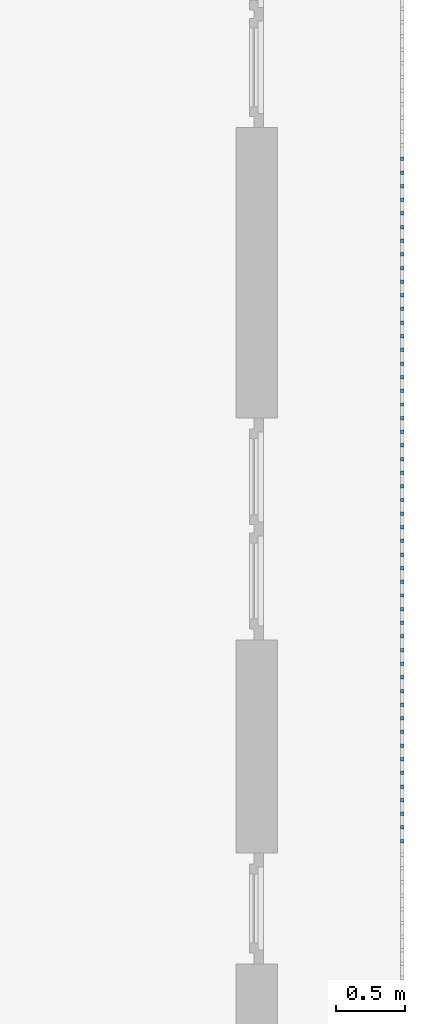
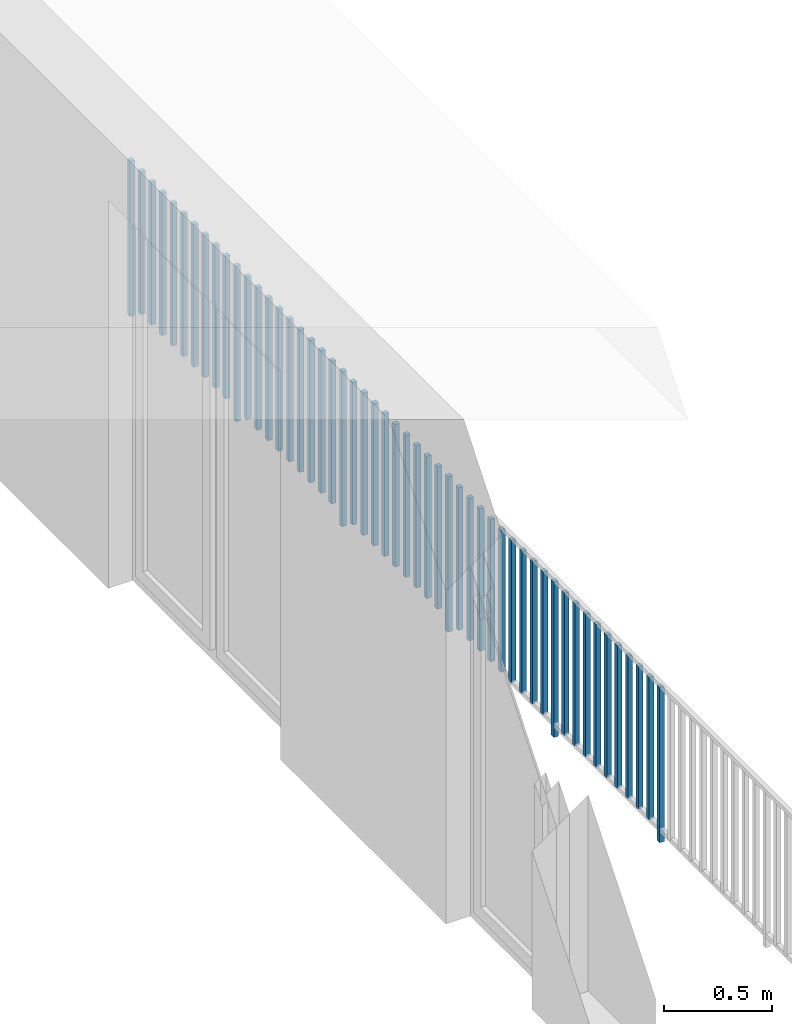
# One storey, part 38 of 48: 51 building element parts, 1 element without a shape of its own.
"""IFC4 building model written with IfcOpenShell, lengths in metres."""

from ifc_helpers import new_model, entity, si_unit, converted_unit, derived_unit, direction, frame, origin_with_axes, place, context, subcontext, project, spatial, polygons, material, type_object, element, aggregate, save


model = new_model("IFC4")

# Units and contexts
model_context = context("Model", 3, precision=1e-05, world=origin_with_axes(), true_north=direction((0.0, 1.0)))
body_context = subcontext(model_context, "Body", "Model", "MODEL_VIEW")
ifc_project = project(units=[si_unit("LENGTHUNIT", "METRE"), si_unit("AREAUNIT", "SQUARE_METRE"), si_unit("VOLUMEUNIT", "CUBIC_METRE"), converted_unit("PLANEANGLEUNIT", "DEGREE", entity("IfcPlaneAngleMeasure", 0.0174532925199), si_unit("PLANEANGLEUNIT", "RADIAN"), dimensions=[0, 0, 0, 0, 0, 0, 0]), converted_unit("TIMEUNIT", "Year", entity("IfcTimeMeasure", 31556926.0), si_unit("TIMEUNIT", "SECOND"), dimensions=[0, 0, 1, 0, 0, 0, 0]), si_unit("MASSUNIT", "GRAM", prefix="KILO"), si_unit("THERMODYNAMICTEMPERATUREUNIT", "DEGREE_CELSIUS"), si_unit("LUMINOUSINTENSITYUNIT", "LUMEN"), si_unit("ENERGYUNIT", "JOULE", prefix="MEGA"), derived_unit("THERMALCONDUCTANCEUNIT", [(si_unit("POWERUNIT", "WATT"), 1), (si_unit("LENGTHUNIT", "METRE"), -1), (si_unit("THERMODYNAMICTEMPERATUREUNIT", "KELVIN"), -1)]), derived_unit("SPECIFICHEATCAPACITYUNIT", [(si_unit("ENERGYUNIT", "JOULE"), 1), (si_unit("MASSUNIT", "GRAM", prefix="KILO"), -1), (si_unit("THERMODYNAMICTEMPERATUREUNIT", "KELVIN"), -1)]), derived_unit("MASSDENSITYUNIT", [(si_unit("MASSUNIT", "GRAM", prefix="KILO"), 1), (si_unit("VOLUMEUNIT", "CUBIC_METRE"), -1)])], contexts=[model_context])

# Site, building, storey
site_placement = place(None, origin_with_axes())
site = spatial("IfcSite", under=ifc_project, at=site_placement, CompositionType="ELEMENT")
building_placement = place(site_placement, origin_with_axes())
building = spatial("IfcBuilding", under=site, at=building_placement, CompositionType="ELEMENT")
storey_placement = place(building_placement, frame((0.0, 0.0, 3.4), z_axis=(0.0, 0.0, 1.0), x_axis=(1.0, 0.0, 0.0)))
storey = spatial("IfcBuildingStorey", under=building, at=storey_placement, Name="1. Geschoss", CompositionType="ELEMENT", Elevation=3.4)

# Railing, building element parts
railing_type = type_object("IfcRailingType", PredefinedType="NOTDEFINED")
railing_placement = place(storey_placement, frame((10.2378006196, 9.82118776896, 0.0), z_axis=(0.0, 0.0, 1.0), x_axis=(1.0, 0.0, 0.0)))
railing = element("IfcRailing", 1, at=railing_placement, inside=storey, type_object=railing_type, PredefinedType="NOTDEFINED")
ifc_material = material()
building_element_part_1_placement = place(railing_placement, origin_with_axes())
building_element_part_1 = element("IfcBuildingElementPart", 2, at=building_element_part_1_placement, material=ifc_material, PredefinedType="NOTDEFINED", context=body_context, shape_type="Tessellation", body=[
    polygons([(0.0125, -17.6875, 0.0), (-0.0125, -17.6875, 0.0), (-0.0125, -17.6875, 0.88), (0.0125, -17.6875, 0.88), (0.0125, -17.7125, 0.0), (-0.0125, -17.7125, 0.0), (-0.0125, -17.7125, 0.88), (0.0125, -17.7125, 0.88)], [[[1, 2, 3, 4]], [[1, 5, 6, 2]], [[2, 6, 7, 3]], [[4, 3, 7, 8]], [[5, 1, 4, 8]], [[6, 5, 8, 7]]], closed=True),
])
building_element_part_2_placement = place(railing_placement, origin_with_axes())
building_element_part_2 = element("IfcBuildingElementPart", 3, at=building_element_part_2_placement, material=ifc_material, PredefinedType="NOTDEFINED", context=body_context, shape_type="Tessellation", body=[
    polygons([(0.0125, -17.5891666667, 0.07), (-0.0125, -17.5891666667, 0.07), (-0.0125, -17.5891666667, 0.8775), (0.0125, -17.5891666667, 0.8775), (0.0125, -17.6141666667, 0.07), (-0.0125, -17.6141666667, 0.07), (-0.0125, -17.6141666667, 0.8775), (0.0125, -17.6141666667, 0.8775)], [[[1, 2, 3, 4]], [[1, 5, 6, 2]], [[2, 6, 7, 3]], [[4, 3, 7, 8]], [[5, 1, 4, 8]], [[6, 5, 8, 7]]], closed=True),
])
building_element_part_3_placement = place(railing_placement, origin_with_axes())
building_element_part_3 = element("IfcBuildingElementPart", 4, at=building_element_part_3_placement, material=ifc_material, PredefinedType="NOTDEFINED", context=body_context, shape_type="Tessellation", body=[
    polygons([(0.0125, -17.4908333333, 0.07), (-0.0125, -17.4908333333, 0.07), (-0.0125, -17.4908333333, 0.8775), (0.0125, -17.4908333333, 0.8775), (0.0125, -17.5158333333, 0.07), (-0.0125, -17.5158333333, 0.07), (-0.0125, -17.5158333333, 0.8775), (0.0125, -17.5158333333, 0.8775)], [[[1, 2, 3, 4]], [[1, 5, 6, 2]], [[2, 6, 7, 3]], [[4, 3, 7, 8]], [[5, 1, 4, 8]], [[6, 5, 8, 7]]], closed=True),
])
building_element_part_4_placement = place(railing_placement, origin_with_axes())
building_element_part_4 = element("IfcBuildingElementPart", 5, at=building_element_part_4_placement, material=ifc_material, PredefinedType="NOTDEFINED", context=body_context, shape_type="Tessellation", body=[
    polygons([(0.0125, -17.3925, 0.07), (-0.0125, -17.3925, 0.07), (-0.0125, -17.3925, 0.8775), (0.0125, -17.3925, 0.8775), (0.0125, -17.4175, 0.07), (-0.0125, -17.4175, 0.07), (-0.0125, -17.4175, 0.8775), (0.0125, -17.4175, 0.8775)], [[[1, 2, 3, 4]], [[1, 5, 6, 2]], [[2, 6, 7, 3]], [[4, 3, 7, 8]], [[5, 1, 4, 8]], [[6, 5, 8, 7]]], closed=True),
])
building_element_part_5_placement = place(railing_placement, origin_with_axes())
building_element_part_5 = element("IfcBuildingElementPart", 6, at=building_element_part_5_placement, material=ifc_material, PredefinedType="NOTDEFINED", context=body_context, shape_type="Tessellation", body=[
    polygons([(0.0125, -17.2941666667, 0.07), (-0.0125, -17.2941666667, 0.07), (-0.0125, -17.2941666667, 0.8775), (0.0125, -17.2941666667, 0.8775), (0.0125, -17.3191666667, 0.07), (-0.0125, -17.3191666667, 0.07), (-0.0125, -17.3191666667, 0.8775), (0.0125, -17.3191666667, 0.8775)], [[[1, 2, 3, 4]], [[1, 5, 6, 2]], [[2, 6, 7, 3]], [[4, 3, 7, 8]], [[5, 1, 4, 8]], [[6, 5, 8, 7]]], closed=True),
])
building_element_part_6_placement = place(railing_placement, origin_with_axes())
building_element_part_6 = element("IfcBuildingElementPart", 7, at=building_element_part_6_placement, material=ifc_material, PredefinedType="NOTDEFINED", context=body_context, shape_type="Tessellation", body=[
    polygons([(0.0125, -17.1958333333, 0.07), (-0.0125, -17.1958333333, 0.07), (-0.0125, -17.1958333333, 0.8775), (0.0125, -17.1958333333, 0.8775), (0.0125, -17.2208333333, 0.07), (-0.0125, -17.2208333333, 0.07), (-0.0125, -17.2208333333, 0.8775), (0.0125, -17.2208333333, 0.8775)], [[[1, 2, 3, 4]], [[1, 5, 6, 2]], [[2, 6, 7, 3]], [[4, 3, 7, 8]], [[5, 1, 4, 8]], [[6, 5, 8, 7]]], closed=True),
])
building_element_part_7_placement = place(railing_placement, origin_with_axes())
building_element_part_7 = element("IfcBuildingElementPart", 8, at=building_element_part_7_placement, material=ifc_material, PredefinedType="NOTDEFINED", context=body_context, shape_type="Tessellation", body=[
    polygons([(0.0125, -17.0975, 0.07), (-0.0125, -17.0975, 0.07), (-0.0125, -17.0975, 0.8775), (0.0125, -17.0975, 0.8775), (0.0125, -17.1225, 0.07), (-0.0125, -17.1225, 0.07), (-0.0125, -17.1225, 0.8775), (0.0125, -17.1225, 0.8775)], [[[1, 2, 3, 4]], [[1, 5, 6, 2]], [[2, 6, 7, 3]], [[4, 3, 7, 8]], [[5, 1, 4, 8]], [[6, 5, 8, 7]]], closed=True),
])
building_element_part_8_placement = place(railing_placement, origin_with_axes())
building_element_part_8 = element("IfcBuildingElementPart", 9, at=building_element_part_8_placement, material=ifc_material, PredefinedType="NOTDEFINED", context=body_context, shape_type="Tessellation", body=[
    polygons([(0.0125, -16.9991666667, 0.07), (-0.0125, -16.9991666667, 0.07), (-0.0125, -16.9991666667, 0.8775), (0.0125, -16.9991666667, 0.8775), (0.0125, -17.0241666667, 0.07), (-0.0125, -17.0241666667, 0.07), (-0.0125, -17.0241666667, 0.8775), (0.0125, -17.0241666667, 0.8775)], [[[1, 2, 3, 4]], [[1, 5, 6, 2]], [[2, 6, 7, 3]], [[4, 3, 7, 8]], [[5, 1, 4, 8]], [[6, 5, 8, 7]]], closed=True),
])
building_element_part_9_placement = place(railing_placement, origin_with_axes())
building_element_part_9 = element("IfcBuildingElementPart", 10, at=building_element_part_9_placement, material=ifc_material, PredefinedType="NOTDEFINED", context=body_context, shape_type="Tessellation", body=[
    polygons([(0.0125, -16.9008333333, 0.07), (-0.0125, -16.9008333333, 0.07), (-0.0125, -16.9008333333, 0.8775), (0.0125, -16.9008333333, 0.8775), (0.0125, -16.9258333333, 0.07), (-0.0125, -16.9258333333, 0.07), (-0.0125, -16.9258333333, 0.8775), (0.0125, -16.9258333333, 0.8775)], [[[1, 2, 3, 4]], [[1, 5, 6, 2]], [[2, 6, 7, 3]], [[4, 3, 7, 8]], [[5, 1, 4, 8]], [[6, 5, 8, 7]]], closed=True),
])
building_element_part_10_placement = place(railing_placement, origin_with_axes())
building_element_part_10 = element("IfcBuildingElementPart", 11, at=building_element_part_10_placement, material=ifc_material, PredefinedType="NOTDEFINED", context=body_context, shape_type="Tessellation", body=[
    polygons([(0.0125, -16.8025, 0.07), (-0.0125, -16.8025, 0.07), (-0.0125, -16.8025, 0.8775), (0.0125, -16.8025, 0.8775), (0.0125, -16.8275, 0.07), (-0.0125, -16.8275, 0.07), (-0.0125, -16.8275, 0.8775), (0.0125, -16.8275, 0.8775)], [[[1, 2, 3, 4]], [[1, 5, 6, 2]], [[2, 6, 7, 3]], [[4, 3, 7, 8]], [[5, 1, 4, 8]], [[6, 5, 8, 7]]], closed=True),
])
building_element_part_11_placement = place(railing_placement, origin_with_axes())
building_element_part_11 = element("IfcBuildingElementPart", 12, at=building_element_part_11_placement, material=ifc_material, PredefinedType="NOTDEFINED", context=body_context, shape_type="Tessellation", body=[
    polygons([(0.0125, -16.7041666667, 0.0), (-0.0125, -16.7041666667, 0.0), (-0.0125, -16.7041666667, 0.88), (0.0125, -16.7041666667, 0.88), (0.0125, -16.7291666667, 0.0), (-0.0125, -16.7291666667, 0.0), (-0.0125, -16.7291666667, 0.88), (0.0125, -16.7291666667, 0.88)], [[[1, 2, 3, 4]], [[1, 5, 6, 2]], [[2, 6, 7, 3]], [[4, 3, 7, 8]], [[5, 1, 4, 8]], [[6, 5, 8, 7]]], closed=True),
])
building_element_part_12_placement = place(railing_placement, origin_with_axes())
building_element_part_12 = element("IfcBuildingElementPart", 13, at=building_element_part_12_placement, material=ifc_material, PredefinedType="NOTDEFINED", context=body_context, shape_type="Tessellation", body=[
    polygons([(0.0125, -16.6058333333, 0.07), (-0.0125, -16.6058333333, 0.07), (-0.0125, -16.6058333333, 0.8775), (0.0125, -16.6058333333, 0.8775), (0.0125, -16.6308333333, 0.07), (-0.0125, -16.6308333333, 0.07), (-0.0125, -16.6308333333, 0.8775), (0.0125, -16.6308333333, 0.8775)], [[[1, 2, 3, 4]], [[1, 5, 6, 2]], [[2, 6, 7, 3]], [[4, 3, 7, 8]], [[5, 1, 4, 8]], [[6, 5, 8, 7]]], closed=True),
])
building_element_part_13_placement = place(railing_placement, origin_with_axes())
building_element_part_13 = element("IfcBuildingElementPart", 14, at=building_element_part_13_placement, material=ifc_material, PredefinedType="NOTDEFINED", context=body_context, shape_type="Tessellation", body=[
    polygons([(0.0125, -16.5075, 0.07), (-0.0125, -16.5075, 0.07), (-0.0125, -16.5075, 0.8775), (0.0125, -16.5075, 0.8775), (0.0125, -16.5325, 0.07), (-0.0125, -16.5325, 0.07), (-0.0125, -16.5325, 0.8775), (0.0125, -16.5325, 0.8775)], [[[1, 2, 3, 4]], [[1, 5, 6, 2]], [[2, 6, 7, 3]], [[4, 3, 7, 8]], [[5, 1, 4, 8]], [[6, 5, 8, 7]]], closed=True),
])
building_element_part_14_placement = place(railing_placement, origin_with_axes())
building_element_part_14 = element("IfcBuildingElementPart", 15, at=building_element_part_14_placement, material=ifc_material, PredefinedType="NOTDEFINED", context=body_context, shape_type="Tessellation", body=[
    polygons([(0.0125, -16.4091666667, 0.07), (-0.0125, -16.4091666667, 0.07), (-0.0125, -16.4091666667, 0.8775), (0.0125, -16.4091666667, 0.8775), (0.0125, -16.4341666667, 0.07), (-0.0125, -16.4341666667, 0.07), (-0.0125, -16.4341666667, 0.8775), (0.0125, -16.4341666667, 0.8775)], [[[1, 2, 3, 4]], [[1, 5, 6, 2]], [[2, 6, 7, 3]], [[4, 3, 7, 8]], [[5, 1, 4, 8]], [[6, 5, 8, 7]]], closed=True),
])
building_element_part_15_placement = place(railing_placement, origin_with_axes())
building_element_part_15 = element("IfcBuildingElementPart", 16, at=building_element_part_15_placement, material=ifc_material, PredefinedType="NOTDEFINED", context=body_context, shape_type="Tessellation", body=[
    polygons([(0.0125, -16.3108333333, 0.07), (-0.0125, -16.3108333333, 0.07), (-0.0125, -16.3108333333, 0.8775), (0.0125, -16.3108333333, 0.8775), (0.0125, -16.3358333333, 0.07), (-0.0125, -16.3358333333, 0.07), (-0.0125, -16.3358333333, 0.8775), (0.0125, -16.3358333333, 0.8775)], [[[1, 2, 3, 4]], [[1, 5, 6, 2]], [[2, 6, 7, 3]], [[4, 3, 7, 8]], [[5, 1, 4, 8]], [[6, 5, 8, 7]]], closed=True),
])
building_element_part_16_placement = place(railing_placement, origin_with_axes())
building_element_part_16 = element("IfcBuildingElementPart", 17, at=building_element_part_16_placement, material=ifc_material, PredefinedType="NOTDEFINED", context=body_context, shape_type="Tessellation", body=[
    polygons([(0.0125, -16.2125, 0.07), (-0.0125, -16.2125, 0.07), (-0.0125, -16.2125, 0.8775), (0.0125, -16.2125, 0.8775), (0.0125, -16.2375, 0.07), (-0.0125, -16.2375, 0.07), (-0.0125, -16.2375, 0.8775), (0.0125, -16.2375, 0.8775)], [[[1, 2, 3, 4]], [[1, 5, 6, 2]], [[2, 6, 7, 3]], [[4, 3, 7, 8]], [[5, 1, 4, 8]], [[6, 5, 8, 7]]], closed=True),
])
building_element_part_17_placement = place(railing_placement, origin_with_axes())
building_element_part_17 = element("IfcBuildingElementPart", 18, at=building_element_part_17_placement, material=ifc_material, PredefinedType="NOTDEFINED", context=body_context, shape_type="Tessellation", body=[
    polygons([(0.0125, -16.1141666667, 0.07), (-0.0125, -16.1141666667, 0.07), (-0.0125, -16.1141666667, 0.8775), (0.0125, -16.1141666667, 0.8775), (0.0125, -16.1391666667, 0.07), (-0.0125, -16.1391666667, 0.07), (-0.0125, -16.1391666667, 0.8775), (0.0125, -16.1391666667, 0.8775)], [[[1, 2, 3, 4]], [[1, 5, 6, 2]], [[2, 6, 7, 3]], [[4, 3, 7, 8]], [[5, 1, 4, 8]], [[6, 5, 8, 7]]], closed=True),
])
building_element_part_18_placement = place(railing_placement, origin_with_axes())
building_element_part_18 = element("IfcBuildingElementPart", 19, at=building_element_part_18_placement, material=ifc_material, PredefinedType="NOTDEFINED", context=body_context, shape_type="Tessellation", body=[
    polygons([(0.0125, -16.0158333333, 0.07), (-0.0125, -16.0158333333, 0.07), (-0.0125, -16.0158333333, 0.8775), (0.0125, -16.0158333333, 0.8775), (0.0125, -16.0408333333, 0.07), (-0.0125, -16.0408333333, 0.07), (-0.0125, -16.0408333333, 0.8775), (0.0125, -16.0408333333, 0.8775)], [[[1, 2, 3, 4]], [[1, 5, 6, 2]], [[2, 6, 7, 3]], [[4, 3, 7, 8]], [[5, 1, 4, 8]], [[6, 5, 8, 7]]], closed=True),
])
building_element_part_19_placement = place(railing_placement, origin_with_axes())
building_element_part_19 = element("IfcBuildingElementPart", 20, at=building_element_part_19_placement, material=ifc_material, PredefinedType="NOTDEFINED", context=body_context, shape_type="Tessellation", body=[
    polygons([(0.0125, -15.9175, 0.07), (-0.0125, -15.9175, 0.07), (-0.0125, -15.9175, 0.8775), (0.0125, -15.9175, 0.8775), (0.0125, -15.9425, 0.07), (-0.0125, -15.9425, 0.07), (-0.0125, -15.9425, 0.8775), (0.0125, -15.9425, 0.8775)], [[[1, 2, 3, 4]], [[1, 5, 6, 2]], [[2, 6, 7, 3]], [[4, 3, 7, 8]], [[5, 1, 4, 8]], [[6, 5, 8, 7]]], closed=True),
])
building_element_part_20_placement = place(railing_placement, origin_with_axes())
building_element_part_20 = element("IfcBuildingElementPart", 21, at=building_element_part_20_placement, material=ifc_material, PredefinedType="NOTDEFINED", context=body_context, shape_type="Tessellation", body=[
    polygons([(0.0125, -15.8191666667, 0.07), (-0.0125, -15.8191666667, 0.07), (-0.0125, -15.8191666667, 0.8775), (0.0125, -15.8191666667, 0.8775), (0.0125, -15.8441666667, 0.07), (-0.0125, -15.8441666667, 0.07), (-0.0125, -15.8441666667, 0.8775), (0.0125, -15.8441666667, 0.8775)], [[[1, 2, 3, 4]], [[1, 5, 6, 2]], [[2, 6, 7, 3]], [[4, 3, 7, 8]], [[5, 1, 4, 8]], [[6, 5, 8, 7]]], closed=True),
])
building_element_part_21_placement = place(railing_placement, origin_with_axes())
building_element_part_21 = element("IfcBuildingElementPart", 22, at=building_element_part_21_placement, material=ifc_material, PredefinedType="NOTDEFINED", context=body_context, shape_type="Tessellation", body=[
    polygons([(0.0125, -15.7208333333, 0.0), (-0.0125, -15.7208333333, 0.0), (-0.0125, -15.7208333333, 0.88), (0.0125, -15.7208333333, 0.88), (0.0125, -15.7458333333, 0.0), (-0.0125, -15.7458333333, 0.0), (-0.0125, -15.7458333333, 0.88), (0.0125, -15.7458333333, 0.88)], [[[1, 2, 3, 4]], [[1, 5, 6, 2]], [[2, 6, 7, 3]], [[4, 3, 7, 8]], [[5, 1, 4, 8]], [[6, 5, 8, 7]]], closed=True),
])
building_element_part_22_placement = place(railing_placement, origin_with_axes())
building_element_part_22 = element("IfcBuildingElementPart", 23, at=building_element_part_22_placement, material=ifc_material, PredefinedType="NOTDEFINED", context=body_context, shape_type="Tessellation", body=[
    polygons([(0.0125, -15.6225, 0.07), (-0.0125, -15.6225, 0.07), (-0.0125, -15.6225, 0.8775), (0.0125, -15.6225, 0.8775), (0.0125, -15.6475, 0.07), (-0.0125, -15.6475, 0.07), (-0.0125, -15.6475, 0.8775), (0.0125, -15.6475, 0.8775)], [[[1, 2, 3, 4]], [[1, 5, 6, 2]], [[2, 6, 7, 3]], [[4, 3, 7, 8]], [[5, 1, 4, 8]], [[6, 5, 8, 7]]], closed=True),
])
building_element_part_23_placement = place(railing_placement, origin_with_axes())
building_element_part_23 = element("IfcBuildingElementPart", 24, at=building_element_part_23_placement, material=ifc_material, PredefinedType="NOTDEFINED", context=body_context, shape_type="Tessellation", body=[
    polygons([(0.0125, -15.5241666667, 0.07), (-0.0125, -15.5241666667, 0.07), (-0.0125, -15.5241666667, 0.8775), (0.0125, -15.5241666667, 0.8775), (0.0125, -15.5491666667, 0.07), (-0.0125, -15.5491666667, 0.07), (-0.0125, -15.5491666667, 0.8775), (0.0125, -15.5491666667, 0.8775)], [[[1, 2, 3, 4]], [[1, 5, 6, 2]], [[2, 6, 7, 3]], [[4, 3, 7, 8]], [[5, 1, 4, 8]], [[6, 5, 8, 7]]], closed=True),
])
building_element_part_24_placement = place(railing_placement, origin_with_axes())
building_element_part_24 = element("IfcBuildingElementPart", 25, at=building_element_part_24_placement, material=ifc_material, PredefinedType="NOTDEFINED", context=body_context, shape_type="Tessellation", body=[
    polygons([(0.0125, -15.4258333333, 0.07), (-0.0125, -15.4258333333, 0.07), (-0.0125, -15.4258333333, 0.8775), (0.0125, -15.4258333333, 0.8775), (0.0125, -15.4508333333, 0.07), (-0.0125, -15.4508333333, 0.07), (-0.0125, -15.4508333333, 0.8775), (0.0125, -15.4508333333, 0.8775)], [[[1, 2, 3, 4]], [[1, 5, 6, 2]], [[2, 6, 7, 3]], [[4, 3, 7, 8]], [[5, 1, 4, 8]], [[6, 5, 8, 7]]], closed=True),
])
building_element_part_25_placement = place(railing_placement, origin_with_axes())
building_element_part_25 = element("IfcBuildingElementPart", 26, at=building_element_part_25_placement, material=ifc_material, PredefinedType="NOTDEFINED", context=body_context, shape_type="Tessellation", body=[
    polygons([(0.0125, -15.3275, 0.07), (-0.0125, -15.3275, 0.07), (-0.0125, -15.3275, 0.8775), (0.0125, -15.3275, 0.8775), (0.0125, -15.3525, 0.07), (-0.0125, -15.3525, 0.07), (-0.0125, -15.3525, 0.8775), (0.0125, -15.3525, 0.8775)], [[[1, 2, 3, 4]], [[1, 5, 6, 2]], [[2, 6, 7, 3]], [[4, 3, 7, 8]], [[5, 1, 4, 8]], [[6, 5, 8, 7]]], closed=True),
])
building_element_part_26_placement = place(railing_placement, origin_with_axes())
building_element_part_26 = element("IfcBuildingElementPart", 27, at=building_element_part_26_placement, material=ifc_material, PredefinedType="NOTDEFINED", context=body_context, shape_type="Tessellation", body=[
    polygons([(0.0125, -15.2291666667, 0.07), (-0.0125, -15.2291666667, 0.07), (-0.0125, -15.2291666667, 0.8775), (0.0125, -15.2291666667, 0.8775), (0.0125, -15.2541666667, 0.07), (-0.0125, -15.2541666667, 0.07), (-0.0125, -15.2541666667, 0.8775), (0.0125, -15.2541666667, 0.8775)], [[[1, 2, 3, 4]], [[1, 5, 6, 2]], [[2, 6, 7, 3]], [[4, 3, 7, 8]], [[5, 1, 4, 8]], [[6, 5, 8, 7]]], closed=True),
])
building_element_part_27_placement = place(railing_placement, origin_with_axes())
building_element_part_27 = element("IfcBuildingElementPart", 28, at=building_element_part_27_placement, material=ifc_material, PredefinedType="NOTDEFINED", context=body_context, shape_type="Tessellation", body=[
    polygons([(0.0125, -15.1308333333, 0.07), (-0.0125, -15.1308333333, 0.07), (-0.0125, -15.1308333333, 0.8775), (0.0125, -15.1308333333, 0.8775), (0.0125, -15.1558333333, 0.07), (-0.0125, -15.1558333333, 0.07), (-0.0125, -15.1558333333, 0.8775), (0.0125, -15.1558333333, 0.8775)], [[[1, 2, 3, 4]], [[1, 5, 6, 2]], [[2, 6, 7, 3]], [[4, 3, 7, 8]], [[5, 1, 4, 8]], [[6, 5, 8, 7]]], closed=True),
])
building_element_part_28_placement = place(railing_placement, origin_with_axes())
building_element_part_28 = element("IfcBuildingElementPart", 29, at=building_element_part_28_placement, material=ifc_material, PredefinedType="NOTDEFINED", context=body_context, shape_type="Tessellation", body=[
    polygons([(0.0125, -15.0325, 0.07), (-0.0125, -15.0325, 0.07), (-0.0125, -15.0325, 0.8775), (0.0125, -15.0325, 0.8775), (0.0125, -15.0575, 0.07), (-0.0125, -15.0575, 0.07), (-0.0125, -15.0575, 0.8775), (0.0125, -15.0575, 0.8775)], [[[1, 2, 3, 4]], [[1, 5, 6, 2]], [[2, 6, 7, 3]], [[4, 3, 7, 8]], [[5, 1, 4, 8]], [[6, 5, 8, 7]]], closed=True),
])
building_element_part_29_placement = place(railing_placement, origin_with_axes())
building_element_part_29 = element("IfcBuildingElementPart", 30, at=building_element_part_29_placement, material=ifc_material, PredefinedType="NOTDEFINED", context=body_context, shape_type="Tessellation", body=[
    polygons([(0.0125, -14.9341666667, 0.07), (-0.0125, -14.9341666667, 0.07), (-0.0125, -14.9341666667, 0.8775), (0.0125, -14.9341666667, 0.8775), (0.0125, -14.9591666667, 0.07), (-0.0125, -14.9591666667, 0.07), (-0.0125, -14.9591666667, 0.8775), (0.0125, -14.9591666667, 0.8775)], [[[1, 2, 3, 4]], [[1, 5, 6, 2]], [[2, 6, 7, 3]], [[4, 3, 7, 8]], [[5, 1, 4, 8]], [[6, 5, 8, 7]]], closed=True),
])
building_element_part_30_placement = place(railing_placement, origin_with_axes())
building_element_part_30 = element("IfcBuildingElementPart", 31, at=building_element_part_30_placement, material=ifc_material, PredefinedType="NOTDEFINED", context=body_context, shape_type="Tessellation", body=[
    polygons([(0.0125, -14.8358333333, 0.07), (-0.0125, -14.8358333333, 0.07), (-0.0125, -14.8358333333, 0.8775), (0.0125, -14.8358333333, 0.8775), (0.0125, -14.8608333333, 0.07), (-0.0125, -14.8608333333, 0.07), (-0.0125, -14.8608333333, 0.8775), (0.0125, -14.8608333333, 0.8775)], [[[1, 2, 3, 4]], [[1, 5, 6, 2]], [[2, 6, 7, 3]], [[4, 3, 7, 8]], [[5, 1, 4, 8]], [[6, 5, 8, 7]]], closed=True),
])
building_element_part_31_placement = place(railing_placement, origin_with_axes())
building_element_part_31 = element("IfcBuildingElementPart", 32, at=building_element_part_31_placement, material=ifc_material, PredefinedType="NOTDEFINED", context=body_context, shape_type="Tessellation", body=[
    polygons([(0.0125, -14.7375, 0.0), (-0.0125, -14.7375, 0.0), (-0.0125, -14.7375, 0.88), (0.0125, -14.7375, 0.88), (0.0125, -14.7625, 0.0), (-0.0125, -14.7625, 0.0), (-0.0125, -14.7625, 0.88), (0.0125, -14.7625, 0.88)], [[[1, 2, 3, 4]], [[1, 5, 6, 2]], [[2, 6, 7, 3]], [[4, 3, 7, 8]], [[5, 1, 4, 8]], [[6, 5, 8, 7]]], closed=True),
])
building_element_part_32_placement = place(railing_placement, origin_with_axes())
building_element_part_32 = element("IfcBuildingElementPart", 33, at=building_element_part_32_placement, material=ifc_material, PredefinedType="NOTDEFINED", context=body_context, shape_type="Tessellation", body=[
    polygons([(0.0125, -14.6391666667, 0.07), (-0.0125, -14.6391666667, 0.07), (-0.0125, -14.6391666667, 0.8775), (0.0125, -14.6391666667, 0.8775), (0.0125, -14.6641666667, 0.07), (-0.0125, -14.6641666667, 0.07), (-0.0125, -14.6641666667, 0.8775), (0.0125, -14.6641666667, 0.8775)], [[[1, 2, 3, 4]], [[1, 5, 6, 2]], [[2, 6, 7, 3]], [[4, 3, 7, 8]], [[5, 1, 4, 8]], [[6, 5, 8, 7]]], closed=True),
])
building_element_part_33_placement = place(railing_placement, origin_with_axes())
building_element_part_33 = element("IfcBuildingElementPart", 34, at=building_element_part_33_placement, material=ifc_material, PredefinedType="NOTDEFINED", context=body_context, shape_type="Tessellation", body=[
    polygons([(0.0125, -14.5408333333, 0.07), (-0.0125, -14.5408333333, 0.07), (-0.0125, -14.5408333333, 0.8775), (0.0125, -14.5408333333, 0.8775), (0.0125, -14.5658333333, 0.07), (-0.0125, -14.5658333333, 0.07), (-0.0125, -14.5658333333, 0.8775), (0.0125, -14.5658333333, 0.8775)], [[[1, 2, 3, 4]], [[1, 5, 6, 2]], [[2, 6, 7, 3]], [[4, 3, 7, 8]], [[5, 1, 4, 8]], [[6, 5, 8, 7]]], closed=True),
])
building_element_part_34_placement = place(railing_placement, origin_with_axes())
building_element_part_34 = element("IfcBuildingElementPart", 35, at=building_element_part_34_placement, material=ifc_material, PredefinedType="NOTDEFINED", context=body_context, shape_type="Tessellation", body=[
    polygons([(0.0125, -14.4425, 0.07), (-0.0125, -14.4425, 0.07), (-0.0125, -14.4425, 0.8775), (0.0125, -14.4425, 0.8775), (0.0125, -14.4675, 0.07), (-0.0125, -14.4675, 0.07), (-0.0125, -14.4675, 0.8775), (0.0125, -14.4675, 0.8775)], [[[1, 2, 3, 4]], [[1, 5, 6, 2]], [[2, 6, 7, 3]], [[4, 3, 7, 8]], [[5, 1, 4, 8]], [[6, 5, 8, 7]]], closed=True),
])
building_element_part_35_placement = place(railing_placement, origin_with_axes())
building_element_part_35 = element("IfcBuildingElementPart", 36, at=building_element_part_35_placement, material=ifc_material, PredefinedType="NOTDEFINED", context=body_context, shape_type="Tessellation", body=[
    polygons([(0.0125, -14.3441666667, 0.07), (-0.0125, -14.3441666667, 0.07), (-0.0125, -14.3441666667, 0.8775), (0.0125, -14.3441666667, 0.8775), (0.0125, -14.3691666667, 0.07), (-0.0125, -14.3691666667, 0.07), (-0.0125, -14.3691666667, 0.8775), (0.0125, -14.3691666667, 0.8775)], [[[1, 2, 3, 4]], [[1, 5, 6, 2]], [[2, 6, 7, 3]], [[4, 3, 7, 8]], [[5, 1, 4, 8]], [[6, 5, 8, 7]]], closed=True),
])
building_element_part_36_placement = place(railing_placement, origin_with_axes())
building_element_part_36 = element("IfcBuildingElementPart", 37, at=building_element_part_36_placement, material=ifc_material, PredefinedType="NOTDEFINED", context=body_context, shape_type="Tessellation", body=[
    polygons([(0.0125, -14.2458333333, 0.07), (-0.0125, -14.2458333333, 0.07), (-0.0125, -14.2458333333, 0.8775), (0.0125, -14.2458333333, 0.8775), (0.0125, -14.2708333333, 0.07), (-0.0125, -14.2708333333, 0.07), (-0.0125, -14.2708333333, 0.8775), (0.0125, -14.2708333333, 0.8775)], [[[1, 2, 3, 4]], [[1, 5, 6, 2]], [[2, 6, 7, 3]], [[4, 3, 7, 8]], [[5, 1, 4, 8]], [[6, 5, 8, 7]]], closed=True),
])
building_element_part_37_placement = place(railing_placement, origin_with_axes())
building_element_part_37 = element("IfcBuildingElementPart", 38, at=building_element_part_37_placement, material=ifc_material, PredefinedType="NOTDEFINED", context=body_context, shape_type="Tessellation", body=[
    polygons([(0.0125, -14.1475, 0.07), (-0.0125, -14.1475, 0.07), (-0.0125, -14.1475, 0.8775), (0.0125, -14.1475, 0.8775), (0.0125, -14.1725, 0.07), (-0.0125, -14.1725, 0.07), (-0.0125, -14.1725, 0.8775), (0.0125, -14.1725, 0.8775)], [[[1, 2, 3, 4]], [[1, 5, 6, 2]], [[2, 6, 7, 3]], [[4, 3, 7, 8]], [[5, 1, 4, 8]], [[6, 5, 8, 7]]], closed=True),
])
building_element_part_38_placement = place(railing_placement, origin_with_axes())
building_element_part_38 = element("IfcBuildingElementPart", 39, at=building_element_part_38_placement, material=ifc_material, PredefinedType="NOTDEFINED", context=body_context, shape_type="Tessellation", body=[
    polygons([(0.0125, -14.0491666667, 0.07), (-0.0125, -14.0491666667, 0.07), (-0.0125, -14.0491666667, 0.8775), (0.0125, -14.0491666667, 0.8775), (0.0125, -14.0741666667, 0.07), (-0.0125, -14.0741666667, 0.07), (-0.0125, -14.0741666667, 0.8775), (0.0125, -14.0741666667, 0.8775)], [[[1, 2, 3, 4]], [[1, 5, 6, 2]], [[2, 6, 7, 3]], [[4, 3, 7, 8]], [[5, 1, 4, 8]], [[6, 5, 8, 7]]], closed=True),
])
building_element_part_39_placement = place(railing_placement, origin_with_axes())
building_element_part_39 = element("IfcBuildingElementPart", 40, at=building_element_part_39_placement, material=ifc_material, PredefinedType="NOTDEFINED", context=body_context, shape_type="Tessellation", body=[
    polygons([(0.0125, -13.9508333333, 0.07), (-0.0125, -13.9508333333, 0.07), (-0.0125, -13.9508333333, 0.8775), (0.0125, -13.9508333333, 0.8775), (0.0125, -13.9758333333, 0.07), (-0.0125, -13.9758333333, 0.07), (-0.0125, -13.9758333333, 0.8775), (0.0125, -13.9758333333, 0.8775)], [[[1, 2, 3, 4]], [[1, 5, 6, 2]], [[2, 6, 7, 3]], [[4, 3, 7, 8]], [[5, 1, 4, 8]], [[6, 5, 8, 7]]], closed=True),
])
building_element_part_40_placement = place(railing_placement, origin_with_axes())
building_element_part_40 = element("IfcBuildingElementPart", 41, at=building_element_part_40_placement, material=ifc_material, PredefinedType="NOTDEFINED", context=body_context, shape_type="Tessellation", body=[
    polygons([(0.0125, -13.8525, 0.07), (-0.0125, -13.8525, 0.07), (-0.0125, -13.8525, 0.8775), (0.0125, -13.8525, 0.8775), (0.0125, -13.8775, 0.07), (-0.0125, -13.8775, 0.07), (-0.0125, -13.8775, 0.8775), (0.0125, -13.8775, 0.8775)], [[[1, 2, 3, 4]], [[1, 5, 6, 2]], [[2, 6, 7, 3]], [[4, 3, 7, 8]], [[5, 1, 4, 8]], [[6, 5, 8, 7]]], closed=True),
])
building_element_part_41_placement = place(railing_placement, origin_with_axes())
building_element_part_41 = element("IfcBuildingElementPart", 42, at=building_element_part_41_placement, material=ifc_material, PredefinedType="NOTDEFINED", context=body_context, shape_type="Tessellation", body=[
    polygons([(0.0125, -13.7541666667, 0.0), (-0.0125, -13.7541666667, 0.0), (-0.0125, -13.7541666667, 0.88), (0.0125, -13.7541666667, 0.88), (0.0125, -13.7791666667, 0.0), (-0.0125, -13.7791666667, 0.0), (-0.0125, -13.7791666667, 0.88), (0.0125, -13.7791666667, 0.88)], [[[1, 2, 3, 4]], [[1, 5, 6, 2]], [[2, 6, 7, 3]], [[4, 3, 7, 8]], [[5, 1, 4, 8]], [[6, 5, 8, 7]]], closed=True),
])
building_element_part_42_placement = place(railing_placement, origin_with_axes())
building_element_part_42 = element("IfcBuildingElementPart", 43, at=building_element_part_42_placement, material=ifc_material, PredefinedType="NOTDEFINED", context=body_context, shape_type="Tessellation", body=[
    polygons([(0.0125, -13.6558333333, 0.07), (-0.0125, -13.6558333333, 0.07), (-0.0125, -13.6558333333, 0.8775), (0.0125, -13.6558333333, 0.8775), (0.0125, -13.6808333333, 0.07), (-0.0125, -13.6808333333, 0.07), (-0.0125, -13.6808333333, 0.8775), (0.0125, -13.6808333333, 0.8775)], [[[1, 2, 3, 4]], [[1, 5, 6, 2]], [[2, 6, 7, 3]], [[4, 3, 7, 8]], [[5, 1, 4, 8]], [[6, 5, 8, 7]]], closed=True),
])
building_element_part_43_placement = place(railing_placement, origin_with_axes())
building_element_part_43 = element("IfcBuildingElementPart", 44, at=building_element_part_43_placement, material=ifc_material, PredefinedType="NOTDEFINED", context=body_context, shape_type="Tessellation", body=[
    polygons([(0.0125, -13.5575, 0.07), (-0.0125, -13.5575, 0.07), (-0.0125, -13.5575, 0.8775), (0.0125, -13.5575, 0.8775), (0.0125, -13.5825, 0.07), (-0.0125, -13.5825, 0.07), (-0.0125, -13.5825, 0.8775), (0.0125, -13.5825, 0.8775)], [[[1, 2, 3, 4]], [[1, 5, 6, 2]], [[2, 6, 7, 3]], [[4, 3, 7, 8]], [[5, 1, 4, 8]], [[6, 5, 8, 7]]], closed=True),
])
building_element_part_44_placement = place(railing_placement, origin_with_axes())
building_element_part_44 = element("IfcBuildingElementPart", 45, at=building_element_part_44_placement, material=ifc_material, PredefinedType="NOTDEFINED", context=body_context, shape_type="Tessellation", body=[
    polygons([(0.0125, -13.4591666667, 0.07), (-0.0125, -13.4591666667, 0.07), (-0.0125, -13.4591666667, 0.8775), (0.0125, -13.4591666667, 0.8775), (0.0125, -13.4841666667, 0.07), (-0.0125, -13.4841666667, 0.07), (-0.0125, -13.4841666667, 0.8775), (0.0125, -13.4841666667, 0.8775)], [[[1, 2, 3, 4]], [[1, 5, 6, 2]], [[2, 6, 7, 3]], [[4, 3, 7, 8]], [[5, 1, 4, 8]], [[6, 5, 8, 7]]], closed=True),
])
building_element_part_45_placement = place(railing_placement, origin_with_axes())
building_element_part_45 = element("IfcBuildingElementPart", 46, at=building_element_part_45_placement, material=ifc_material, PredefinedType="NOTDEFINED", context=body_context, shape_type="Tessellation", body=[
    polygons([(0.0125, -13.3608333333, 0.07), (-0.0125, -13.3608333333, 0.07), (-0.0125, -13.3608333333, 0.8775), (0.0125, -13.3608333333, 0.8775), (0.0125, -13.3858333333, 0.07), (-0.0125, -13.3858333333, 0.07), (-0.0125, -13.3858333333, 0.8775), (0.0125, -13.3858333333, 0.8775)], [[[1, 2, 3, 4]], [[1, 5, 6, 2]], [[2, 6, 7, 3]], [[4, 3, 7, 8]], [[5, 1, 4, 8]], [[6, 5, 8, 7]]], closed=True),
])
building_element_part_46_placement = place(railing_placement, origin_with_axes())
building_element_part_46 = element("IfcBuildingElementPart", 47, at=building_element_part_46_placement, material=ifc_material, PredefinedType="NOTDEFINED", context=body_context, shape_type="Tessellation", body=[
    polygons([(0.0125, -13.2625, 0.07), (-0.0125, -13.2625, 0.07), (-0.0125, -13.2625, 0.8775), (0.0125, -13.2625, 0.8775), (0.0125, -13.2875, 0.07), (-0.0125, -13.2875, 0.07), (-0.0125, -13.2875, 0.8775), (0.0125, -13.2875, 0.8775)], [[[1, 2, 3, 4]], [[1, 5, 6, 2]], [[2, 6, 7, 3]], [[4, 3, 7, 8]], [[5, 1, 4, 8]], [[6, 5, 8, 7]]], closed=True),
])
building_element_part_47_placement = place(railing_placement, origin_with_axes())
building_element_part_47 = element("IfcBuildingElementPart", 48, at=building_element_part_47_placement, material=ifc_material, PredefinedType="NOTDEFINED", context=body_context, shape_type="Tessellation", body=[
    polygons([(0.0125, -13.1641666667, 0.07), (-0.0125, -13.1641666667, 0.07), (-0.0125, -13.1641666667, 0.8775), (0.0125, -13.1641666667, 0.8775), (0.0125, -13.1891666667, 0.07), (-0.0125, -13.1891666667, 0.07), (-0.0125, -13.1891666667, 0.8775), (0.0125, -13.1891666667, 0.8775)], [[[1, 2, 3, 4]], [[1, 5, 6, 2]], [[2, 6, 7, 3]], [[4, 3, 7, 8]], [[5, 1, 4, 8]], [[6, 5, 8, 7]]], closed=True),
])
building_element_part_48_placement = place(railing_placement, origin_with_axes())
building_element_part_48 = element("IfcBuildingElementPart", 49, at=building_element_part_48_placement, material=ifc_material, PredefinedType="NOTDEFINED", context=body_context, shape_type="Tessellation", body=[
    polygons([(0.0125, -13.0658333333, 0.07), (-0.0125, -13.0658333333, 0.07), (-0.0125, -13.0658333333, 0.8775), (0.0125, -13.0658333333, 0.8775), (0.0125, -13.0908333333, 0.07), (-0.0125, -13.0908333333, 0.07), (-0.0125, -13.0908333333, 0.8775), (0.0125, -13.0908333333, 0.8775)], [[[1, 2, 3, 4]], [[1, 5, 6, 2]], [[2, 6, 7, 3]], [[4, 3, 7, 8]], [[5, 1, 4, 8]], [[6, 5, 8, 7]]], closed=True),
])
building_element_part_49_placement = place(railing_placement, origin_with_axes())
building_element_part_49 = element("IfcBuildingElementPart", 50, at=building_element_part_49_placement, material=ifc_material, PredefinedType="NOTDEFINED", context=body_context, shape_type="Tessellation", body=[
    polygons([(0.0125, -12.9675, 0.07), (-0.0125, -12.9675, 0.07), (-0.0125, -12.9675, 0.8775), (0.0125, -12.9675, 0.8775), (0.0125, -12.9925, 0.07), (-0.0125, -12.9925, 0.07), (-0.0125, -12.9925, 0.8775), (0.0125, -12.9925, 0.8775)], [[[1, 2, 3, 4]], [[1, 5, 6, 2]], [[2, 6, 7, 3]], [[4, 3, 7, 8]], [[5, 1, 4, 8]], [[6, 5, 8, 7]]], closed=True),
])
building_element_part_50_placement = place(railing_placement, origin_with_axes())
building_element_part_50 = element("IfcBuildingElementPart", 51, at=building_element_part_50_placement, material=ifc_material, PredefinedType="NOTDEFINED", context=body_context, shape_type="Tessellation", body=[
    polygons([(0.0125, -12.8691666667, 0.07), (-0.0125, -12.8691666667, 0.07), (-0.0125, -12.8691666667, 0.8775), (0.0125, -12.8691666667, 0.8775), (0.0125, -12.8941666667, 0.07), (-0.0125, -12.8941666667, 0.07), (-0.0125, -12.8941666667, 0.8775), (0.0125, -12.8941666667, 0.8775)], [[[1, 2, 3, 4]], [[1, 5, 6, 2]], [[2, 6, 7, 3]], [[4, 3, 7, 8]], [[5, 1, 4, 8]], [[6, 5, 8, 7]]], closed=True),
])
building_element_part_51_placement = place(railing_placement, origin_with_axes())
building_element_part_51 = element("IfcBuildingElementPart", 52, at=building_element_part_51_placement, material=ifc_material, PredefinedType="NOTDEFINED", context=body_context, shape_type="Tessellation", body=[
    polygons([(0.0125, -12.7708333333, 0.0), (-0.0125, -12.7708333333, 0.0), (-0.0125, -12.7708333333, 0.88), (0.0125, -12.7708333333, 0.88), (0.0125, -12.7958333333, 0.0), (-0.0125, -12.7958333333, 0.0), (-0.0125, -12.7958333333, 0.88), (0.0125, -12.7958333333, 0.88)], [[[1, 2, 3, 4]], [[1, 5, 6, 2]], [[2, 6, 7, 3]], [[4, 3, 7, 8]], [[5, 1, 4, 8]], [[6, 5, 8, 7]]], closed=True),
])
aggregate(railing, [building_element_part_1, building_element_part_2, building_element_part_3, building_element_part_4, building_element_part_5, building_element_part_6, building_element_part_7, building_element_part_8, building_element_part_9, building_element_part_10, building_element_part_11, building_element_part_12, building_element_part_13, building_element_part_14, building_element_part_15, building_element_part_16, building_element_part_17, building_element_part_18, building_element_part_19, building_element_part_20, building_element_part_21, building_element_part_22, building_element_part_23, building_element_part_24, building_element_part_25, building_element_part_26, building_element_part_27, building_element_part_28, building_element_part_29, building_element_part_30, building_element_part_31, building_element_part_32, building_element_part_33, building_element_part_34, building_element_part_35, building_element_part_36, building_element_part_37, building_element_part_38, building_element_part_39, building_element_part_40, building_element_part_41, building_element_part_42, building_element_part_43, building_element_part_44, building_element_part_45, building_element_part_46, building_element_part_47, building_element_part_48, building_element_part_49, building_element_part_50, building_element_part_51])

save(model, "model.ifc")
